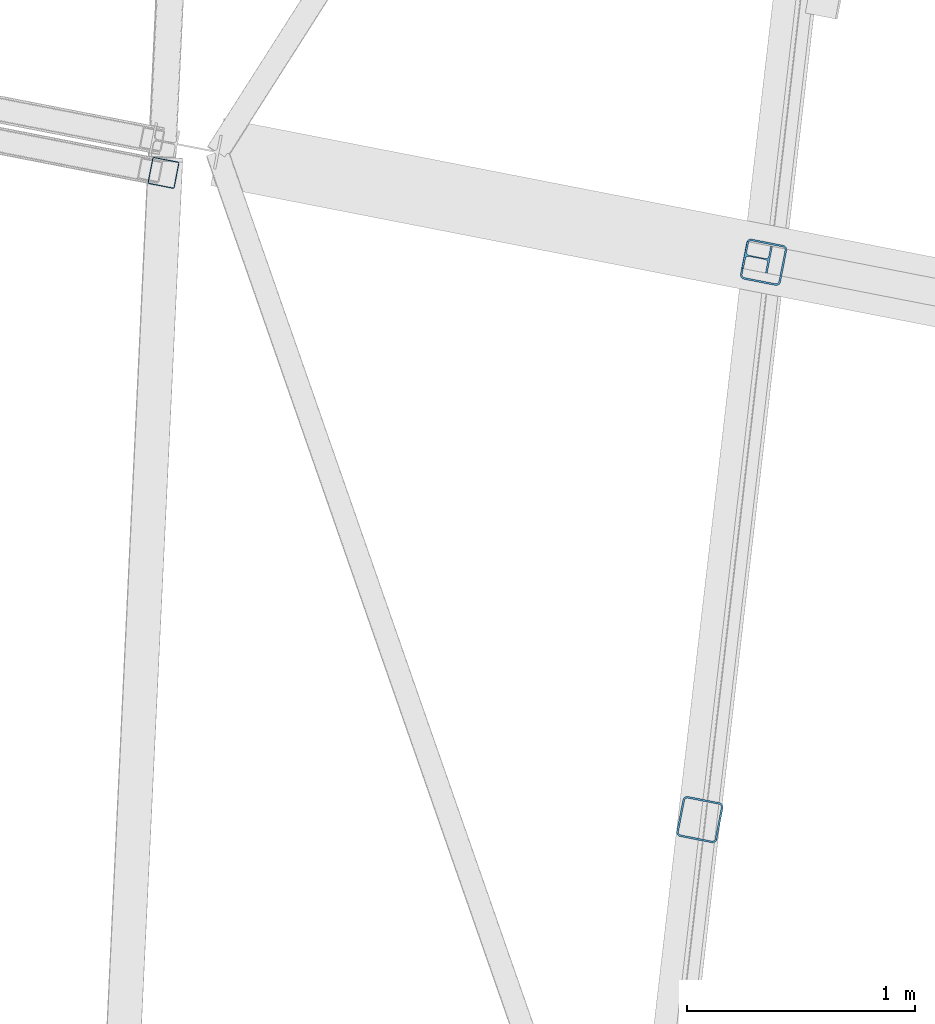
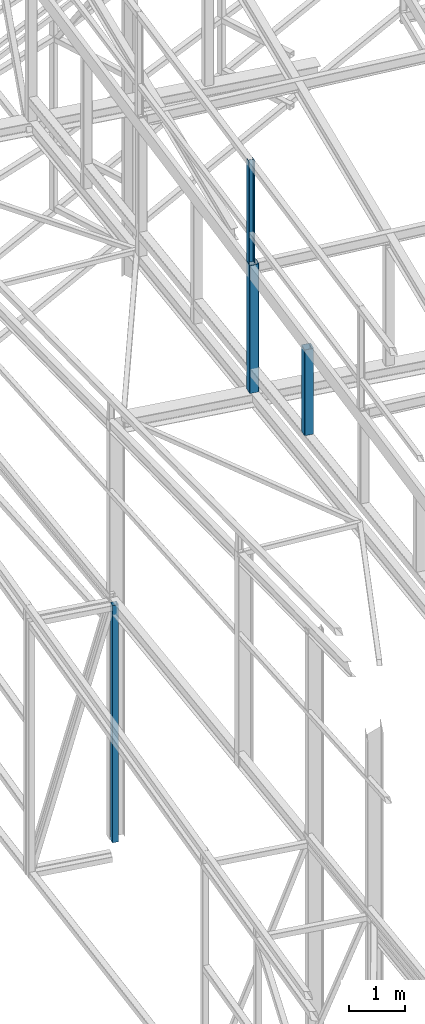
# One storey, part 71 of 215: 4 beams, 4 elements without a shape of their own.
"""IFC2X3 building model written with IfcOpenShell, lengths in millimetres."""

from ifc_helpers import new_model, si_unit, frame, origin_with_axes, origin_2d_with_axis, place, context, subcontext, project, spatial, hollow_rectangle, i_section, extrude, clip, halfspace, material, type_object, element, aggregate, save


model = new_model("IFC2X3")

# Units and contexts
model_context = context("Model", 3, precision=1e-05, world=origin_with_axes())
body_context = subcontext(model_context, "Body", "Model", "MODEL_VIEW")
ifc_project = project(units=[si_unit("LENGTHUNIT", "METRE", prefix="MILLI"), si_unit("AREAUNIT", "SQUARE_METRE"), si_unit("VOLUMEUNIT", "CUBIC_METRE"), si_unit("MASSUNIT", "GRAM", prefix="KILO"), si_unit("TIMEUNIT", "SECOND"), si_unit("PLANEANGLEUNIT", "RADIAN"), si_unit("SOLIDANGLEUNIT", "STERADIAN"), si_unit("THERMODYNAMICTEMPERATUREUNIT", "DEGREE_CELSIUS"), si_unit("LUMINOUSINTENSITYUNIT", "LUMEN")], contexts=[model_context])

# Site, building, storey
site_placement = place(None, origin_with_axes())
site = spatial("IfcSite", under=ifc_project, at=site_placement, CompositionType="ELEMENT")
building_placement = place(site_placement, origin_with_axes())
building = spatial("IfcBuilding", under=site, at=building_placement, Name="Undefined", CompositionType="ELEMENT")
storey_placement = place(building_placement, origin_with_axes())
storey = spatial("IfcBuildingStorey", under=building, at=storey_placement, Name="Undefined", CompositionType="ELEMENT", Elevation=0.0)

# Assembly, beam
assembly_1_placement = place(storey_placement, origin_with_axes())
assembly_1 = element("IfcElementAssembly", 1, at=assembly_1_placement, inside=storey, Name="Steel Assembly", AssemblyPlace="NOTDEFINED", PredefinedType="RIGID_FRAME")
ifc_material_1 = material(Name="STEEL/S235JR")
beam_type_1 = type_object("IfcBeamType", PredefinedType="NOTDEFINED")
beam_1_placement = place(assembly_1_placement, frame((38566.886812179, 44140.7819148648, 5190.81618439351), z_axis=(-0.981475092367809, 0.1915897780718, 0.0), x_axis=(0.0, 0.0, -1.0)))
beam_1 = element("IfcBeam", 2, at=beam_1_placement, type_object=beam_type_1, material=ifc_material_1, Name="LISSE", context=body_context, shape_type="SweptSolid", body=[
    extrude(hollow_rectangle(XDim=120.0, YDim=120.0, WallThickness=4.0, InnerFilletRadius=4.0, OuterFilletRadius=8.0, at=origin_2d_with_axis()), frame((5190.81469193345, -7.27595761418343e-12, 7.27595761418343e-12), z_axis=(-1.0, 0.0, 0.0), x_axis=(-6.93889390390723e-18, -1.0, -3.46944695195361e-18)), (0.0, 0.0, 1.0), 5190.8),
])
aggregate(assembly_1, [beam_1])

assembly_2_placement = place(storey_placement, origin_with_axes())
assembly_2 = element("IfcElementAssembly", 3, at=assembly_2_placement, inside=storey, Name="Steel Assembly", AssemblyPlace="NOTDEFINED", PredefinedType="RIGID_FRAME")
ifc_material_2 = material(Name="STEEL/S275JR")
beam_type_2 = type_object("IfcBeamType", PredefinedType="NOTDEFINED")
beam_2_placement = place(assembly_2_placement, frame((40923.7342546293, 41298.8460691296, 11712.3339048946), z_axis=(-0.981422412140383, 0.191859451027444, 0.0), x_axis=(0.0, 0.0, -1.0)))
beam_2 = element("IfcBeam", 4, at=beam_2_placement, type_object=beam_type_2, material=ifc_material_2, Name="MONTANT", context=body_context, shape_type="Clipping", body=[
    clip(extrude(hollow_rectangle(XDim=180.0, YDim=180.0, WallThickness=8.0, InnerFilletRadius=12.0, OuterFilletRadius=20.0, at=origin_2d_with_axis()), frame((1883.93970555305, 0.0, 0.0), z_axis=(-1.0, 0.0, 0.0), x_axis=(-6.93889390390723e-18, -1.0, -3.46944695195361e-18)), (0.0, 0.0, 1.0), 1883.9), halfspace(frame((1888.27408900269, -177.014007724225, 103.998136372124), z_axis=(-0.998757541180045, -0.0496840699304531, 0.00385579189483438), x_axis=(0.0, -0.0773735506072624, -0.997002173350904)), True)),
])
aggregate(assembly_2, [beam_2])

assembly_3_placement = place(storey_placement, origin_with_axes())
assembly_3 = element("IfcElementAssembly", 5, at=assembly_3_placement, inside=storey, Name="Steel Assembly", AssemblyPlace="NOTDEFINED", PredefinedType="RIGID_FRAME")
beam_3_placement = place(assembly_3_placement, frame((41203.6022867398, 43747.8111974103, 11978.1959567946), z_axis=(-0.981422412140383, 0.191859451027444, 0.0), x_axis=(0.0, 0.0, -1.0)))
beam_3 = element("IfcBeam", 6, at=beam_3_placement, type_object=beam_type_2, material=ifc_material_2, Name="MONTANT", context=body_context, shape_type="SweptSolid", body=[
    extrude(hollow_rectangle(XDim=180.0, YDim=180.0, WallThickness=8.0, InnerFilletRadius=12.0, OuterFilletRadius=20.0, at=origin_2d_with_axis()), frame((2802.08220396607, 0.0, 0.0), z_axis=(-1.0, 0.0, 0.0), x_axis=(-6.93889390390723e-18, -1.0, -3.46944695195361e-18)), (0.0, 0.0, 1.0), 2802.1),
])
aggregate(assembly_3, [beam_3])

assembly_4_placement = place(storey_placement, origin_with_axes())
assembly_4 = element("IfcElementAssembly", 7, at=assembly_4_placement, inside=storey, Name="Steel Assembly", AssemblyPlace="NOTDEFINED", PredefinedType="RIGID_FRAME")
beam_type_3 = type_object("IfcBeamType", Name="HEA120", PredefinedType="NOTDEFINED")
beam_4_placement = place(assembly_4_placement, frame((41175.1176581844, 43769.091913879, 14219.9969937122), z_axis=(0.981422409205525, -0.19185946604018, 1.89999991602007e-08), x_axis=(0.0, 0.0, -1.0)))
beam_4 = element("IfcBeam", 8, at=beam_4_placement, type_object=beam_type_3, material=ifc_material_2, ObjectType="HEA120", context=body_context, shape_type="SweptSolid", body=[
    extrude(i_section(OverallWidth=120.0, OverallDepth=114.0, WebThickness=5.0, FlangeThickness=8.0, FilletRadius=12.0, at=origin_2d_with_axis()), frame((2241.80103482447, -7.27595761418343e-12, 0.0), z_axis=(-1.0, 0.0, 0.0), x_axis=(-6.93889390390723e-18, -1.0, -3.46944695195361e-18)), (0.0, 0.0, 1.0), 2241.8),
])
aggregate(assembly_4, [beam_4])

save(model, "model.ifc")
